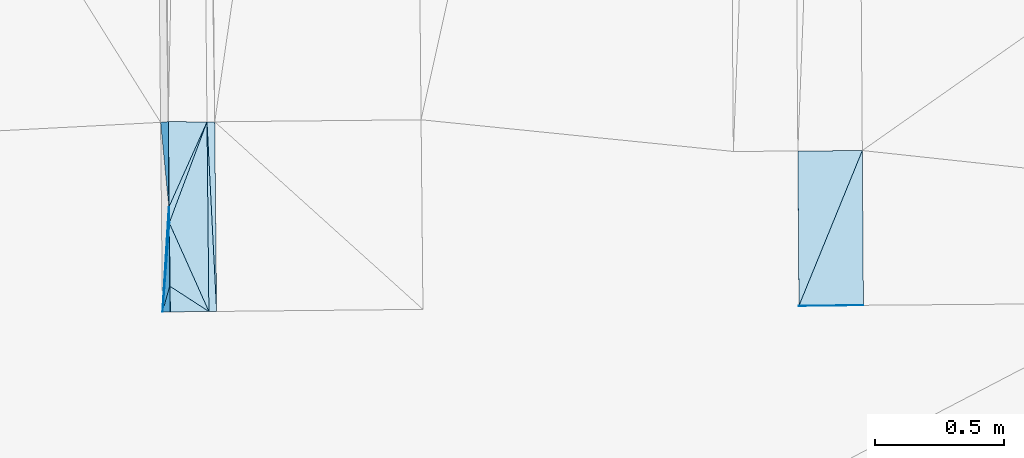
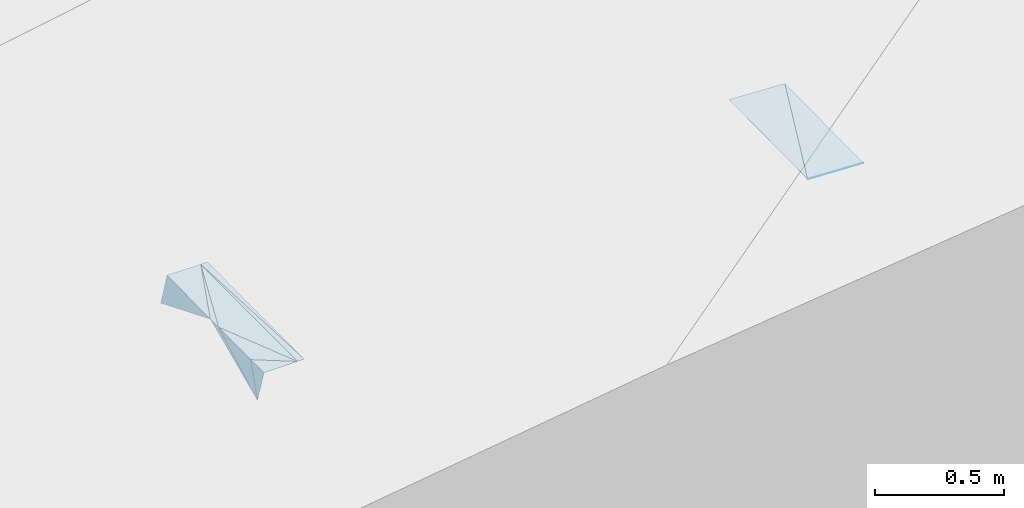
# One storey, part 169 of 275: 14 plates.
"""IFC2X3 building model written with IfcOpenShell, lengths in millimetres."""

from ifc_helpers import new_model, si_unit, frame, origin_with_axes, place, context, subcontext, project, spatial, polyline, outline, extrude, material, type_object, element, save


model = new_model("IFC2X3")

# Units and contexts
model_context = context("Model", 3, precision=1e-05, world=origin_with_axes())
body_context = subcontext(model_context, "Body", "Model", "MODEL_VIEW")
ifc_project = project(units=[si_unit("LENGTHUNIT", "METRE", prefix="MILLI"), si_unit("AREAUNIT", "SQUARE_METRE"), si_unit("VOLUMEUNIT", "CUBIC_METRE"), si_unit("MASSUNIT", "GRAM", prefix="KILO"), si_unit("TIMEUNIT", "SECOND"), si_unit("PLANEANGLEUNIT", "RADIAN"), si_unit("SOLIDANGLEUNIT", "STERADIAN"), si_unit("THERMODYNAMICTEMPERATUREUNIT", "DEGREE_CELSIUS"), si_unit("LUMINOUSINTENSITYUNIT", "LUMEN")], contexts=[model_context])

# Site, building, storey
site_placement = place(None, origin_with_axes())
site = spatial("IfcSite", under=ifc_project, at=site_placement, CompositionType="ELEMENT")
building_placement = place(site_placement, origin_with_axes())
building = spatial("IfcBuilding", under=site, at=building_placement, Name="Undefined", CompositionType="ELEMENT")
storey_placement = place(building_placement, origin_with_axes())
storey = spatial("IfcBuildingStorey", under=building, at=storey_placement, Name="Undefined", CompositionType="ELEMENT", Elevation=0.0)

# Plates
ifc_material = material()
plate_type_1 = type_object("IfcPlateType", PredefinedType="NOTDEFINED")
for number, where, z_axis, x_axis, name in (
    (1, (-54852.3307084825, 23750.418241986, 41808.5967249839), (-0.0500710992119092, 0.0198466474213601, -0.998548444297944), (-0.00717814700245087, 0.999769566744913, 0.0202308580218287), "00_PR"),
    (2, (-54606.6444721764, 24352.1975435379, 41808.2377242298), (-0.0500710992119092, 0.0198466474213601, -0.998548444297944), (0.00717814702692045, -0.99976956674462, -0.0202308580276383), "00_PR"),
):
    element("IfcPlate", number, at=place(storey_placement, frame(where, z_axis=z_axis, x_axis=x_axis)), inside=storey, type_object=plate_type_1, material=ifc_material, Name=name, context=body_context, shape_type="SweptSolid", body=[
        extrude(outline(polyline([(0.0, 0.0), (600.122863769531, 2.5465851649642e-10), (599.869812011719, 250.312622070313), (0.0, 0.0)])), frame((-8.85201319254618e-08, 2.18876761149539e-07, -0.5000001331573), z_axis=(0.0, 0.0, 1.0), x_axis=(1.0, 0.0, 0.0)), (0.0, 0.0, 1.0), 1.0),
    ])
plate_type_2 = type_object("IfcPlateType", PredefinedType="NOTDEFINED")
plate_1_placement = place(storey_placement, frame((-57293.4880637808, 24071.7306992812, 41769.7591112511), z_axis=(0.00125315108754059, 0.020689987627542, -0.999785153932746), x_axis=(0.349757226887547, 0.936630659862939, 0.0198214339705259)))
element("IfcPlate", 3, at=plate_1_placement, inside=storey, type_object=plate_type_2, material=ifc_material, Name="00_PR", context=body_context, shape_type="SweptSolid", body=[
    extrude(outline(polyline([(0.0, 0.0), (418.032318115234, 9.16770659387112e-10), (-268.250091552734, 264.055572509766), (0.0, 0.0)])), frame((-8.85201319254618e-08, 2.18876761149539e-07, -0.5000001331573), z_axis=(0.0, 0.0, 1.0), x_axis=(1.0, 0.0, 0.0)), (0.0, 0.0, 1.0), 1.0),
])
plate_type_3 = type_object("IfcPlateType", PredefinedType="NOTDEFINED")
plate_2_placement = place(storey_placement, frame((-57117.2708408412, 24463.570667465, 41778.6452087161), z_axis=(0.0197856395539543, 0.0208711856784386, -0.999586375495293), x_axis=(0.00998969401719688, -0.99973630771906, -0.0206765819637763)))
element("IfcPlate", 4, at=plate_2_placement, inside=storey, type_object=plate_type_3, material=ifc_material, Name="00_PR", context=body_context, shape_type="SweptSolid", body=[
    extrude(outline(polyline([(0.0, 0.0), (735.324645996094, 5.74800651520491e-10), (0.0106543088331819, 30.0056095123291), (0.0, 0.0)])), frame((-8.85201319254618e-08, 2.18876761149539e-07, -0.5000001331573), z_axis=(0.0, 0.0, 1.0), x_axis=(1.0, 0.0, 0.0)), (0.0, 0.0, 1.0), 1.0),
])
plate_3_placement = place(storey_placement, frame((-57109.9251778789, 23728.4399397984, 41763.4412105228), z_axis=(0.0197829334125956, 0.0208711596541503, -0.999586429599904), x_axis=(-0.999749241011076, -0.0100802540576798, -0.0199960890153615)))
element("IfcPlate", 5, at=plate_3_placement, inside=storey, type_object=plate_type_3, material=ifc_material, Name="00_PR", context=body_context, shape_type="SweptSolid", body=[
    extrude(outline(polyline([(0.0, 0.0), (30.0058670043945, -3.27418092638254e-11), (29.6351127624512, 735.328979492188), (0.0, 0.0)])), frame((-8.85201319254618e-08, 2.18876761149539e-07, -0.5000001331573), z_axis=(0.0, 0.0, 1.0), x_axis=(1.0, 0.0, 0.0)), (0.0, 0.0, 1.0), 1.0),
])
plate_type_4 = type_object("IfcPlateType", PredefinedType="NOTDEFINED")
plate_4_placement = place(storey_placement, frame((-54852.3306406611, 23750.4081189837, 41808.5966248429), z_axis=(-0.0499359056623596, -0.000405082524720759, -0.998752342292036), x_axis=(0.998726606735248, 0.00716996497765696, -0.0499375269843939)))
element("IfcPlate", 6, at=plate_4_placement, inside=storey, type_object=plate_type_4, material=ifc_material, Name="00_PR", context=body_context, shape_type="SweptSolid", body=[
    extrude(outline(polyline([(0.0, 0.0), (250.312759399414, -3.52883944287896e-10), (0.00120188284199685, 1.28996074199677), (0.0, 0.0)])), frame((-8.85201319254618e-08, 2.18876761149539e-07, -0.5000001331573), z_axis=(0.0, 0.0, 1.0), x_axis=(1.0, 0.0, 0.0)), (0.0, 0.0, 1.0), 1.0),
])
plate_type_5 = type_object("IfcPlateType", PredefinedType="NOTDEFINED")
plate_5_placement = place(storey_placement, frame((-57326.7851148845, 24461.481114704, 41658.4233112863), z_axis=(0.970358642107879, 0.0117177390356915, -0.241385169963782), x_axis=(0.241083955999609, 0.0225474160350607, 0.970242310038951)))
element("IfcPlate", 7, at=plate_5_placement, inside=storey, type_object=plate_type_5, material=ifc_material, Name="00_PR", context=body_context, shape_type="SweptSolid", body=[
    extrude(outline(polyline([(0.0, 0.0), (123.68147277832, 2.9831426218152e-10), (109.795745849609, 331.451629638672), (0.0, 0.0)])), frame((-8.85201319254618e-08, 2.18876761149539e-07, -0.5000001331573), z_axis=(0.0, 0.0, 1.0), x_axis=(1.0, 0.0, 0.0)), (0.0, 0.0, 1.0), 1.0),
])
plate_type_6 = type_object("IfcPlateType", PredefinedType="NOTDEFINED")
plate_6_placement = place(storey_placement, frame((-57293.0024196659, 24071.7258496132, 41770.1427598069), z_axis=(0.972537086389837, 0.0109920227065675, -0.232488259990014), x_axis=(0.00640360101644612, -0.99976972066184, -0.0204816879618808)))
element("IfcPlate", 8, at=plate_6_placement, inside=storey, type_object=plate_type_6, material=ifc_material, Name="00_PR", context=body_context, shape_type="SweptSolid", body=[
    extrude(outline(polyline([(0.0, 0.0), (245.194641113281, 1.74622982740402e-10), (347.752899169922, 123.197723388672), (0.0, 0.0)])), frame((-8.85201319254618e-08, 2.18876761149539e-07, -0.5000001331573), z_axis=(0.0, 0.0, 1.0), x_axis=(1.0, 0.0, 0.0)), (0.0, 0.0, 1.0), 1.0),
])
plate_type_7 = type_object("IfcPlateType", PredefinedType="NOTDEFINED")
plate_7_placement = place(storey_placement, frame((-57319.446488547, 23726.3344724092, 41643.1968619454), z_axis=(0.9569869340901, 0.0326843800439817, -0.288284129431316), x_axis=(0.0578784149859446, 0.952155243117643, 0.300084125008801)))
element("IfcPlate", 9, at=plate_7_placement, inside=storey, type_object=plate_type_7, material=ifc_material, Name="00_PR", context=body_context, shape_type="SweptSolid", body=[
    extrude(outline(polyline([(0.0, 0.0), (426.703674316406, -1.16415321826935e-10), (368.492706298828, 17.9688091278076), (0.0, 0.0)])), frame((-8.85201319254618e-08, 2.18876761149539e-07, -0.5000001331573), z_axis=(0.0, 0.0, 1.0), x_axis=(1.0, 0.0, 0.0)), (0.0, 0.0, 1.0), 1.0),
])
plate_type_8 = type_object("IfcPlateType", PredefinedType="NOTDEFINED")
plate_8_placement = place(storey_placement, frame((-57291.4336335242, 23826.5941444169, 41765.1157474159), z_axis=(0.969852925895147, 0.0239296532430157, -0.242513244645096), x_axis=(0.0199231910217902, -0.999621722058583, -0.0189599379783397)))
element("IfcPlate", 10, at=plate_8_placement, inside=storey, type_object=plate_type_8, material=ifc_material, Name="00_PR", context=body_context, shape_type="SweptSolid", body=[
    extrude(outline(polyline([(0.0, 0.0), (100.000328063965, 1.16415321826935e-10), (101.979286193848, 123.677398681641), (0.0, 0.0)])), frame((-8.85201319254618e-08, 2.18876761149539e-07, -0.5000001331573), z_axis=(0.0, 0.0, 1.0), x_axis=(1.0, 0.0, 0.0)), (0.0, 0.0, 1.0), 1.0),
])
plate_type_9 = type_object("IfcPlateType", PredefinedType="NOTDEFINED")
plate_9_placement = place(storey_placement, frame((-57147.2787967143, 24463.2730198897, 41778.0451202289), z_axis=(0.000143916972853314, 0.0215754210676751, -0.99976721315197), x_axis=(-0.408341917922918, -0.912615296972816, -0.0197534249752442)))
element("IfcPlate", 11, at=plate_9_placement, inside=storey, type_object=plate_type_9, material=ifc_material, Name="00_PR", context=body_context, shape_type="SweptSolid", body=[
    extrude(outline(polyline([(0.0, 0.0), (362.316925048828, 8.14907252788544e-10), (60.408073425293, 137.491958618164), (0.0, 0.0)])), frame((-8.85201319254618e-08, 2.18876761149539e-07, -0.5000001331573), z_axis=(0.0, 0.0, 1.0), x_axis=(1.0, 0.0, 0.0)), (0.0, 0.0, 1.0), 1.0),
])
plate_type_10 = type_object("IfcPlateType", PredefinedType="NOTDEFINED")
plate_10_placement = place(storey_placement, frame((-57147.2756112032, 24463.2715949603, 41778.0451022538), z_axis=(0.006515360061151, 0.0187253570476816, -0.999803436224696), x_axis=(-0.349757226883717, -0.936630659864364, -0.0198214339707962)))
element("IfcPlate", 12, at=plate_10_placement, inside=storey, type_object=plate_type_10, material=ifc_material, Name="00_PR", context=body_context, shape_type="SweptSolid", body=[
    extrude(outline(polyline([(0.0, 0.0), (418.032318115234, 9.16770659387112e-10), (361.590667724609, 22.9289379119873), (0.0, 0.0)])), frame((-8.85201319254618e-08, 2.18876761149539e-07, -0.5000001331573), z_axis=(0.0, 0.0, 1.0), x_axis=(1.0, 0.0, 0.0)), (0.0, 0.0, 1.0), 1.0),
])
plate_type_11 = type_object("IfcPlateType", PredefinedType="NOTDEFINED")
plate_11_placement = place(storey_placement, frame((-57139.9330123066, 23728.1372812609, 41762.8411088616), z_axis=(0.000799226611336671, 0.0204872185387341, -0.999789795463711), x_axis=(-0.839242433370788, 0.543656627174, 0.0104694679744927)))
element("IfcPlate", 13, at=plate_11_placement, inside=storey, type_object=plate_type_11, material=ifc_material, Name="00_PR", context=body_context, shape_type="SweptSolid", body=[
    extrude(outline(polyline([(0.0, 0.0), (181.098022460938, -5.5297277867794e-10), (315.739318847656, 204.919815063477), (0.0, 0.0)])), frame((-8.85201319254618e-08, 2.18876761149539e-07, -0.5000001331573), z_axis=(0.0, 0.0, 1.0), x_axis=(1.0, 0.0, 0.0)), (0.0, 0.0, 1.0), 1.0),
])
plate_type_12 = type_object("IfcPlateType", PredefinedType="NOTDEFINED")
plate_12_placement = place(storey_placement, frame((-57139.9335074613, 23728.1365175392, 41762.8410935279), z_axis=(-0.000190537793813818, 0.0189599055872218, -0.999820226678513), x_axis=(-0.999949507473874, -0.0100490050630302, -1.41638265643986e-11)))
element("IfcPlate", 14, at=plate_12_placement, inside=storey, type_object=plate_type_12, material=ifc_material, Name="00_PR", context=body_context, shape_type="SweptSolid", body=[
    extrude(outline(polyline([(0.0, 0.0), (150.000396728516, -5.0931703299284e-11), (150.988098144531, 99.9954452514648), (0.0, 0.0)])), frame((-8.85201319254618e-08, 2.18876761149539e-07, -0.5000001331573), z_axis=(0.0, 0.0, 1.0), x_axis=(1.0, 0.0, 0.0)), (0.0, 0.0, 1.0), 1.0),
])

save(model, "model.ifc")
